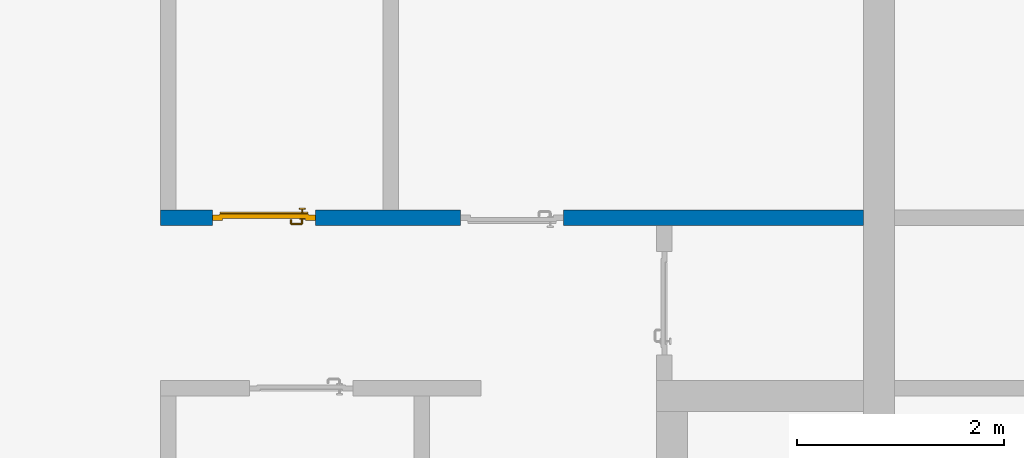
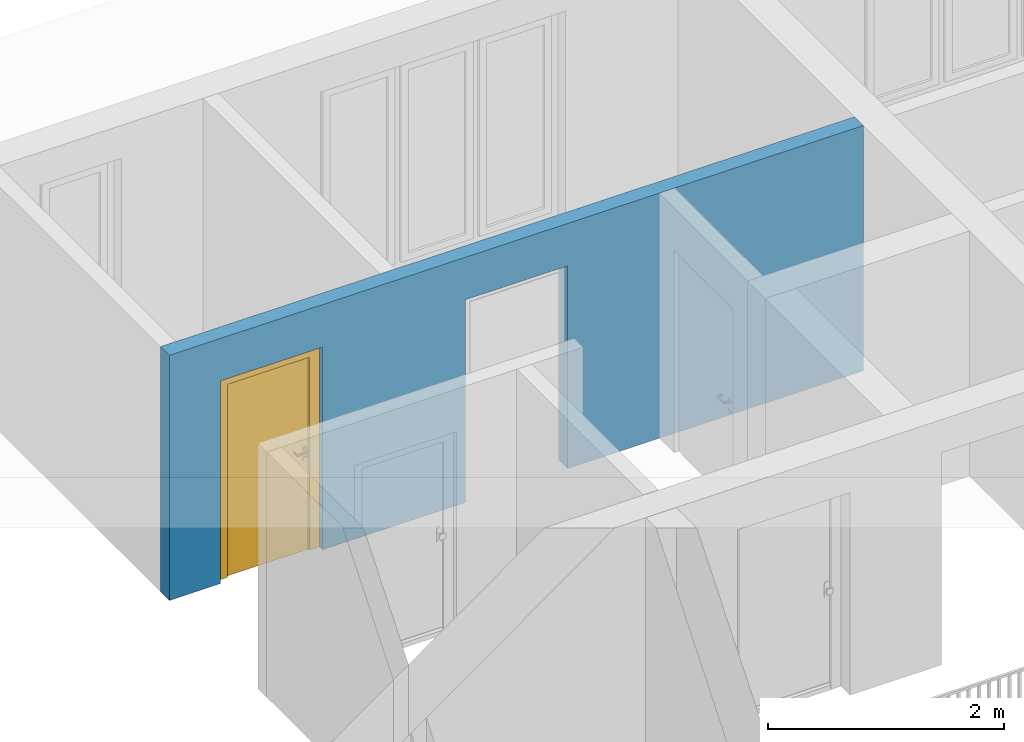
# One storey, part 25 of 54: 1 door, 1 wall, 2 openings.
"""IFC4 building model written with IfcOpenShell, lengths in metres."""

from ifc_helpers import new_model, entity, si_unit, converted_unit, derived_unit, direction, frame, origin_with_axes, place, context, subcontext, project, spatial, polygons, source, transform, mapped, material, type_object, element, fill, save


model = new_model("IFC4")

# Units and contexts
model_context = context("Model", 3, precision=1e-05, world=origin_with_axes(), true_north=direction((0.0, 1.0)))
body_context = subcontext(model_context, "Body", "Model", "MODEL_VIEW")
ifc_project = project(units=[si_unit("LENGTHUNIT", "METRE"), si_unit("AREAUNIT", "SQUARE_METRE"), si_unit("VOLUMEUNIT", "CUBIC_METRE"), converted_unit("PLANEANGLEUNIT", "DEGREE", entity("IfcPlaneAngleMeasure", 0.0174532925199), si_unit("PLANEANGLEUNIT", "RADIAN"), dimensions=[0, 0, 0, 0, 0, 0, 0]), converted_unit("TIMEUNIT", "Year", entity("IfcTimeMeasure", 31556926.0), si_unit("TIMEUNIT", "SECOND"), dimensions=[0, 0, 1, 0, 0, 0, 0]), si_unit("MASSUNIT", "GRAM", prefix="KILO"), si_unit("THERMODYNAMICTEMPERATUREUNIT", "DEGREE_CELSIUS"), si_unit("LUMINOUSINTENSITYUNIT", "LUMEN"), si_unit("ENERGYUNIT", "JOULE", prefix="MEGA"), derived_unit("THERMALCONDUCTANCEUNIT", [(si_unit("POWERUNIT", "WATT"), 1), (si_unit("LENGTHUNIT", "METRE"), -1), (si_unit("THERMODYNAMICTEMPERATUREUNIT", "KELVIN"), -1)]), derived_unit("SPECIFICHEATCAPACITYUNIT", [(si_unit("ENERGYUNIT", "JOULE"), 1), (si_unit("MASSUNIT", "GRAM", prefix="KILO"), -1), (si_unit("THERMODYNAMICTEMPERATUREUNIT", "KELVIN"), -1)]), derived_unit("MASSDENSITYUNIT", [(si_unit("MASSUNIT", "GRAM", prefix="KILO"), 1), (si_unit("VOLUMEUNIT", "CUBIC_METRE"), -1)])], contexts=[model_context])

# Site, building, storey
site_placement = place(None, origin_with_axes())
site = spatial("IfcSite", under=ifc_project, at=site_placement, CompositionType="ELEMENT")
building_placement = place(site_placement, origin_with_axes())
building = spatial("IfcBuilding", under=site, at=building_placement, CompositionType="ELEMENT")
storey_placement = place(building_placement, frame((0.0, 0.0, 9.18), z_axis=(0.0, 0.0, 1.0), x_axis=(1.0, 0.0, 0.0)))
storey = spatial("IfcBuildingStorey", under=building, at=storey_placement, Name="3. Geschoss", CompositionType="ELEMENT", Elevation=9.18)

# Wall, openings, door
ifc_material = material()
wall_type = type_object("IfcWallType", Name="150", PredefinedType="NOTDEFINED")
wall_placement = place(storey_placement, frame((-7.5421993804, 5.47118776896, 0.0), z_axis=(0.0, 0.0, 1.0), x_axis=(1.0, 0.0, 0.0)))
wall = element("IfcWall", 1, at=wall_placement, inside=storey, type_object=wall_type, material=ifc_material, Name="Wand-002", PredefinedType="NOTDEFINED", context=body_context, shape_type="Tessellation", body=[
    polygons([(2.9, 0.15, 2.1), (2.9, 0.15, 0.0), (1.5, 0.15, 0.0), (1.5, 0.15, 2.1), (0.5, 0.15, 2.1), (0.5, 0.15, 0.0), (0.0, 0.15, 0.0), (0.0, 0.15, 2.54), (6.8, 0.15, 2.54), (6.8, 0.15, 0.0), (3.9, 0.15, 0.0), (3.9, 0.15, 2.1), (2.9, 0.05, 2.1), (2.9, 0.05, 0.0), (2.9, 0.0, 0.0), (1.5, 0.0, 0.0), (1.5, 0.1, 0.0), (1.5, 0.1, 2.1), (0.5, 0.1, 2.1), (0.5, 0.1, 0.0), (0.5, 0.0, 0.0), (0.0, 0.0, 0.0), (0.0, 0.0, 2.54), (6.8, 0.0, 2.54), (6.8, 0.0, 0.0), (3.9, 0.05, 0.0), (3.9, 0.0, 0.0), (3.9, 0.05, 2.1), (2.9, 0.0, 2.1), (3.9, 0.0, 2.1), (0.5, 0.0, 2.1), (1.5, 0.0, 2.1)], [[[1, 2, 3, 4, 5, 6, 7, 8, 9, 10, 11, 12]], [[2, 1, 13, 14]], [[2, 14, 15, 16, 17, 3]], [[4, 3, 17, 18]], [[5, 4, 18, 19]], [[6, 5, 19, 20]], [[6, 20, 21, 22, 7]], [[22, 23, 8, 7]], [[23, 24, 9, 8]], [[10, 9, 24, 25]], [[26, 11, 10, 25, 27]], [[12, 11, 26, 28]], [[1, 12, 28, 13]], [[14, 13, 29, 15]], [[16, 15, 29, 30, 27, 25, 24, 23, 22, 21, 31, 32]], [[16, 32, 18, 17]], [[32, 31, 19, 18]], [[31, 21, 20, 19]], [[28, 26, 27, 30]], [[13, 28, 30, 29]]], closed=True),
])
opening_1_placement = place(wall_placement, frame((1.0, 0.0, 0.0), z_axis=(0.0, 0.0, 1.0), x_axis=(1.0, 0.0, 0.0)))
opening_1 = element("IfcOpeningElement", 2, at=opening_1_placement, cuts=wall, context=body_context, identifier="Reference", shape_type="Tessellation", body=[
    polygons([(-0.5, 0.1, 0.0), (-0.5, 0.1, 2.1), (-0.5, 0.151, 2.1), (-0.5, 0.151, 0.0), (-0.5, -0.001, 0.0), (-0.5, -0.001, 2.1), (0.5, 0.1, 2.1), (0.5, 0.151, 2.1), (0.5, -0.001, 2.1), (0.5, 0.151, 0.0), (0.5, 0.1, 0.0), (0.5, -0.001, 0.0)], [[[1, 2, 3, 4]], [[2, 1, 5, 6]], [[7, 8, 3, 2, 6, 9]], [[8, 10, 4, 3]], [[1, 4, 10, 11, 12, 5]], [[6, 5, 12, 9]], [[7, 11, 10, 8]], [[11, 7, 9, 12]]], closed=True),
])
opening_2_placement = place(wall_placement, frame((3.4, 0.0, 0.0), z_axis=(0.0, 0.0, 1.0), x_axis=(1.0, 0.0, 0.0)))
element("IfcOpeningElement", 3, at=opening_2_placement, cuts=wall, context=body_context, identifier="Reference", shape_type="Tessellation", body=[
    polygons([(0.5, 0.05, 0.0), (0.5, 0.05, 2.1), (0.5, -0.001, 2.1), (0.5, -0.001, 0.0), (0.5, 0.151, 0.0), (0.5, 0.151, 2.1), (-0.5, 0.05, 2.1), (-0.5, -0.001, 2.1), (-0.5, 0.151, 2.1), (-0.5, -0.001, 0.0), (-0.5, 0.05, 0.0), (-0.5, 0.151, 0.0)], [[[1, 2, 3, 4]], [[2, 1, 5, 6]], [[7, 8, 3, 2, 6, 9]], [[8, 10, 4, 3]], [[1, 4, 10, 11, 12, 5]], [[6, 5, 12, 9]], [[7, 11, 10, 8]], [[11, 7, 9, 12]]], closed=True),
])
door_type = type_object("IfcDoorType", Name="Eingang 01 1-Fl 26", OperationType="SINGLE_SWING_LEFT", PredefinedType="DOOR")
shared_shape = source(origin_with_axes(), body_context, "Body", "Tessellation", [
    polygons([(-0.5, -0.05, 0.0), (-0.5, -0.05, 2.1), (-0.5, -0.03, 2.1), (-0.5, -0.03, 0.0), (-0.4, -0.05, 0.0), (-0.4, -0.05, 2.0), (-0.1301, -0.05, 2.0), (-0.0001, -0.05, 2.0), (0.4, -0.05, 2.0), (0.4, -0.05, 0.0), (0.5, -0.05, 0.0), (0.5, -0.05, 2.1), (0.5, -0.03, 2.1), (0.5, -0.03, 0.0), (0.4, -0.03, 0.0), (0.4, -0.03, 2.0), (-0.0001, -0.03, 2.0), (-0.1301, -0.03, 2.0), (-0.4, -0.03, 2.0), (-0.4, -0.03, 0.0)], [[[1, 2, 3, 4]], [[1, 5, 6, 7, 8, 9, 10, 11, 12, 2]], [[2, 12, 13, 3]], [[4, 3, 13, 14, 15, 16, 17, 18, 19, 20]], [[5, 1, 4, 20]], [[6, 5, 20, 19]], [[7, 6, 19, 18]], [[8, 7, 18, 17]], [[9, 8, 17, 16]], [[10, 9, 16, 15]], [[11, 10, 15, 14]], [[12, 11, 14, 13]]], closed=True),
    polygons([(-0.5, -0.03, 0.0), (-0.5, -0.03, 2.1), (-0.5, 0.0, 2.1), (-0.5, 0.0, 0.0), (-0.43, -0.03, 0.0), (-0.43, -0.03, 2.03), (-0.1001, -0.03, 2.03), (-0.0301, -0.03, 2.03), (0.43, -0.03, 2.03), (0.43, -0.03, 0.0), (0.5, -0.03, 0.0), (0.5, -0.03, 2.1), (0.5, 0.0, 2.1), (0.5, 0.0, 0.0), (0.43, 0.0, 0.0), (0.43, 0.0, 2.03), (-0.0301, 0.0, 2.03), (-0.1001, 0.0, 2.03), (-0.43, 0.0, 2.03), (-0.43, 0.0, 0.0)], [[[1, 2, 3, 4]], [[1, 5, 6, 7, 8, 9, 10, 11, 12, 2]], [[2, 12, 13, 3]], [[4, 3, 13, 14, 15, 16, 17, 18, 19, 20]], [[5, 1, 4, 20]], [[6, 5, 20, 19]], [[7, 6, 19, 18]], [[8, 7, 18, 17]], [[9, 8, 17, 16]], [[10, 9, 16, 15]], [[11, 10, 15, 14]], [[12, 11, 14, 13]]], closed=True),
    polygons([(-0.43, 0.01, 0.0), (-0.43, 0.01, 2.03), (0.43, 0.01, 2.03), (0.43, 0.01, 0.0), (-0.43, -0.03, 0.0), (-0.43, -0.03, 2.03), (0.43, -0.03, 2.03), (0.43, -0.03, 0.0)], [[[1, 2, 3, 4]], [[1, 5, 6, 2]], [[2, 6, 7, 3]], [[3, 7, 8, 4]], [[4, 8, 5, 1]], [[8, 7, 6, 5]]], closed=True),
    polygons([(-0.425, 0.03, 0.0), (-0.425, 0.03, 0.05), (0.425, 0.03, 0.05), (0.425, 0.03, 0.0), (-0.425, 0.01, 0.0), (-0.425, 0.01, 0.07), (-0.425, 0.015, 0.07), (0.425, 0.015, 0.07), (0.425, 0.01, 0.07), (0.425, 0.01, 0.0)], [[[1, 2, 3, 4]], [[1, 5, 6, 7, 2]], [[2, 7, 8, 3]], [[4, 3, 8, 9, 10]], [[5, 1, 4, 10]], [[6, 5, 10, 9]], [[7, 6, 9, 8]]], closed=True),
    polygons([(0.3835, -0.04, 1.0733826859), (0.3835, -0.0399, 1.0733826859), (0.37, -0.0399, 1.077), (0.37, -0.04, 1.077), (0.393382685902, -0.04, 1.0635), (0.393382685902, -0.0399, 1.0635), (0.3835, -0.0301, 1.0733826859), (0.37, -0.0301, 1.077), (0.3565, -0.0399, 1.0733826859), (0.3565, -0.04, 1.0733826859), (0.346617314098, -0.04, 1.0635), (0.343, -0.04, 1.05), (0.346617314098, -0.04, 1.0365), (0.3565, -0.04, 1.0266173141), (0.37, -0.04, 1.023), (0.3835, -0.04, 1.0266173141), (0.393382685902, -0.04, 1.0365), (0.397, -0.04, 1.05), (0.397, -0.0399, 1.05), (0.393382685902, -0.0301, 1.0635), (0.3835, -0.03, 1.0733826859), (0.37, -0.03, 1.077), (0.3565, -0.0301, 1.0733826859), (0.346617314098, -0.0399, 1.0635), (0.343, -0.0399, 1.05), (0.346617314098, -0.0399, 1.0365), (0.3565, -0.0399, 1.0266173141), (0.37, -0.0399, 1.023), (0.3835, -0.0399, 1.0266173141), (0.393382685902, -0.0399, 1.0365), (0.397, -0.0301, 1.05), (0.393382685902, -0.03, 1.0635), (0.397, -0.03, 1.05), (0.393382685902, -0.03, 1.0365), (0.3835, -0.03, 1.0266173141), (0.37, -0.03, 1.023), (0.3565, -0.03, 1.0266173141), (0.346617314098, -0.03, 1.0365), (0.343, -0.03, 1.05), (0.346617314098, -0.03, 1.0635), (0.3565, -0.03, 1.0733826859), (0.346617314098, -0.0301, 1.0635), (0.343, -0.0301, 1.05), (0.346617314098, -0.0301, 1.0365), (0.3565, -0.0301, 1.0266173141), (0.37, -0.0301, 1.023), (0.3835, -0.0301, 1.0266173141), (0.393382685902, -0.0301, 1.0365)], [[[1, 2, 3, 4]], [[5, 6, 2, 1]], [[2, 7, 8, 3]], [[4, 3, 9, 10]], [[4, 10, 11, 12, 13, 14, 15, 16, 17, 18, 5, 1]], [[18, 19, 6, 5]], [[6, 20, 7, 2]], [[7, 21, 22, 8]], [[3, 8, 23, 9]], [[10, 9, 24, 11]], [[11, 24, 25, 12]], [[12, 25, 26, 13]], [[13, 26, 27, 14]], [[14, 27, 28, 15]], [[15, 28, 29, 16]], [[16, 29, 30, 17]], [[17, 30, 19, 18]], [[19, 31, 20, 6]], [[20, 32, 21, 7]], [[22, 21, 32, 33, 34, 35, 36, 37, 38, 39, 40, 41]], [[8, 22, 41, 23]], [[9, 23, 42, 24]], [[24, 42, 43, 25]], [[25, 43, 44, 26]], [[26, 44, 45, 27]], [[27, 45, 46, 28]], [[28, 46, 47, 29]], [[29, 47, 48, 30]], [[30, 48, 31, 19]], [[31, 33, 32, 20]], [[48, 34, 33, 31]], [[47, 35, 34, 48]], [[46, 36, 35, 47]], [[45, 37, 36, 46]], [[44, 38, 37, 45]], [[43, 39, 38, 44]], [[42, 40, 39, 43]], [[23, 41, 40, 42]]], closed=True),
    polygons([(0.362532169224, -0.04, 0.959692280177), (0.363279754556, -0.04, 0.961639806549), (0.35655, -0.04, 0.973296083362), (0.346703916638, -0.04, 0.96345), (0.365, -0.04, 0.952886751346), (0.365, -0.04, 0.9544), (0.362532169224, -0.039, 0.959692280177), (0.363279754556, -0.039, 0.961639806549), (0.364624817685, -0.039, 0.965143815798), (0.364624817685, -0.04, 0.965143815798), (0.37, -0.04, 0.967425445323), (0.37, -0.04, 0.9769), (0.346617314098, -0.04, 0.9635), (0.3565, -0.04, 0.973382685902), (0.365, -0.04, 0.95), (0.3431, -0.04, 0.95), (0.365, -0.04, 0.947113248654), (0.365, -0.04, 0.941339745962), (0.365, -0.04, 0.9375), (0.365, -0.039, 0.9375), (0.365, -0.039, 0.941339745962), (0.365, -0.039, 0.947113248654), (0.365, -0.039, 0.95), (0.365, -0.039, 0.952886751346), (0.365, -0.039, 0.9544), (0.347569942042, -0.039, 0.96295), (0.35705, -0.039, 0.972430057958), (0.37, -0.039, 0.9759), (0.37, -0.039, 0.967425445323), (0.375375182315, -0.04, 0.965143815798), (0.376720245444, -0.04, 0.961639806549), (0.38345, -0.04, 0.973296083362), (0.37, -0.04, 0.977), (0.343, -0.04, 0.95), (0.346617314098, -0.0399, 0.9635), (0.3565, -0.0399, 0.973382685902), (0.346703916638, -0.04, 0.93655), (0.35655, -0.04, 0.926703916638), (0.37, -0.04, 0.9231), (0.37, -0.04, 0.9325), (0.366464466094, -0.04, 0.933964466094), (0.366464466094, -0.039, 0.933964466094), (0.37, -0.039, 0.9241), (0.35705, -0.039, 0.927569942042), (0.37, -0.039, 0.9325), (0.347569942042, -0.039, 0.93705), (0.3441, -0.039, 0.95), (0.347483339502, -0.039, 0.963), (0.357, -0.039, 0.972516660498), (0.37, -0.039, 0.976), (0.375375182315, -0.039, 0.965143815798), (0.38295, -0.039, 0.972430057958), (0.376720245444, -0.039, 0.961639806549), (0.377467830776, -0.039, 0.959692280177), (0.377467830776, -0.04, 0.959692280177), (0.375, -0.04, 0.9544), (0.375, -0.04, 0.952886751346), (0.393296083362, -0.04, 0.96345), (0.3835, -0.04, 0.973382685902), (0.37, -0.0399, 0.977), (0.346617314098, -0.04, 0.9365), (0.343, -0.0399, 0.95), (0.346617314098, -0.0301, 0.9635), (0.3565, -0.0301, 0.973382685902), (0.3565, -0.04, 0.926617314098), (0.37, -0.04, 0.923), (0.38345, -0.04, 0.926703916638), (0.375, -0.04, 0.941339745962), (0.375, -0.04, 0.9375), (0.373535533906, -0.04, 0.933964466094), (0.37, -0.039, 0.924), (0.357, -0.039, 0.927483339502), (0.38295, -0.039, 0.927569942042), (0.373535533906, -0.039, 0.933964466094), (0.375, -0.039, 0.9375), (0.375, -0.039, 0.941339745962), (0.347483339502, -0.039, 0.937), (0.344, -0.039, 0.95), (0.347483339502, -0.0389, 0.963), (0.357, -0.0389, 0.972516660498), (0.37, -0.0389, 0.976), (0.383, -0.039, 0.972516660498), (0.392430057958, -0.039, 0.96295), (0.375, -0.039, 0.952886751346), (0.375, -0.039, 0.9544), (0.375, -0.039, 0.95), (0.375, -0.039, 0.947113248654), (0.375, -0.04, 0.947113248654), (0.375, -0.04, 0.95), (0.3969, -0.04, 0.95), (0.393382685902, -0.04, 0.9635), (0.3835, -0.0399, 0.973382685902), (0.37, -0.0301, 0.977), (0.346617314098, -0.0399, 0.9365), (0.343, -0.0301, 0.95), (0.346617314098, -0.03, 0.9635), (0.3565, -0.03, 0.973382685902), (0.3565, -0.0399, 0.926617314098), (0.3835, -0.04, 0.926617314098), (0.37, -0.0399, 0.923), (0.393296083362, -0.04, 0.93655), (0.383, -0.039, 0.927483339502), (0.37, -0.0389, 0.924), (0.357, -0.0389, 0.927483339502), (0.392430057958, -0.039, 0.93705), (0.347483339502, -0.0389, 0.937), (0.344, -0.0389, 0.95), (0.347483339502, -0.0301, 0.963), (0.357, -0.0301, 0.972516660498), (0.37, -0.0301, 0.976), (0.383, -0.0389, 0.972516660498), (0.392516660498, -0.039, 0.963), (0.3959, -0.039, 0.95), (0.397, -0.04, 0.95), (0.393382685902, -0.0399, 0.9635), (0.3835, -0.0301, 0.973382685902), (0.37, -0.03, 0.977), (0.346617314098, -0.0301, 0.9365), (0.343, -0.03, 0.95), (0.346703916638, -0.03, 0.96345), (0.35655, -0.03, 0.973296083362), (0.3565, -0.0301, 0.926617314098), (0.393382685902, -0.04, 0.9365), (0.3835, -0.0399, 0.926617314098), (0.37, -0.0301, 0.923), (0.392516660498, -0.039, 0.937), (0.383, -0.0389, 0.927483339502), (0.37, -0.0301, 0.924), (0.357, -0.0301, 0.927483339502), (0.347483339502, -0.0301, 0.937), (0.344, -0.0301, 0.95), (0.347483339502, -0.03, 0.963), (0.357, -0.03, 0.972516660498), (0.37, -0.03, 0.976), (0.383, -0.0301, 0.972516660498), (0.392516660498, -0.0389, 0.963), (0.396, -0.039, 0.95), (0.397, -0.0399, 0.95), (0.393382685902, -0.0301, 0.9635), (0.3835, -0.03, 0.973382685902), (0.37, -0.03, 0.9769), (0.346617314098, -0.03, 0.9365), (0.3431, -0.03, 0.95), (0.347396736961, -0.03, 0.96305), (0.35695, -0.03, 0.972603263039), (0.3565, -0.03, 0.926617314098), (0.393382685902, -0.0399, 0.9365), (0.3835, -0.0301, 0.926617314098), (0.37, -0.03, 0.923), (0.392516660498, -0.0389, 0.937), (0.383, -0.0301, 0.927483339502), (0.37, -0.03, 0.924), (0.357, -0.03, 0.927483339502), (0.347483339502, -0.03, 0.937), (0.344, -0.03, 0.95), (0.37, -0.03, 0.9761), (0.383, -0.03, 0.972516660498), (0.392516660498, -0.0301, 0.963), (0.396, -0.0389, 0.95), (0.397, -0.0301, 0.95), (0.393382685902, -0.03, 0.9635), (0.38345, -0.03, 0.973296083362), (0.346703916638, -0.03, 0.93655), (0.3439, -0.03, 0.95), (0.35655, -0.03, 0.926703916638), (0.393382685902, -0.0301, 0.9365), (0.3835, -0.03, 0.926617314098), (0.37, -0.03, 0.9231), (0.392516660498, -0.0301, 0.937), (0.383, -0.03, 0.927483339502), (0.37, -0.03, 0.9239), (0.35695, -0.03, 0.927396736961), (0.347396736961, -0.03, 0.93695), (0.38305, -0.03, 0.972603263039), (0.392516660498, -0.03, 0.963), (0.396, -0.0301, 0.95), (0.397, -0.03, 0.95), (0.393296083362, -0.03, 0.96345), (0.393382685902, -0.03, 0.9365), (0.38345, -0.03, 0.926703916638), (0.392516660498, -0.03, 0.937), (0.38305, -0.03, 0.927396736961), (0.392603263039, -0.03, 0.96305), (0.396, -0.03, 0.95), (0.3969, -0.03, 0.95), (0.393296083362, -0.03, 0.93655), (0.392603263039, -0.03, 0.93695), (0.3961, -0.03, 0.95)], [[[1, 2, 3, 4, 5, 6]], [[1, 7, 8, 9, 10, 2]], [[10, 11, 12, 3, 2]], [[13, 4, 3, 14]], [[15, 5, 4, 16]], [[6, 5, 15, 17, 18, 19, 20, 21, 22, 23, 24, 25]], [[6, 25, 7, 1]], [[7, 25, 24, 26, 27, 8]], [[9, 8, 27, 28, 29]], [[10, 9, 29, 11]], [[30, 31, 32, 12, 11]], [[14, 3, 12, 33]], [[34, 16, 4, 13]], [[35, 13, 14, 36]], [[17, 15, 16, 37]], [[18, 17, 37, 38]], [[38, 39, 40, 41, 19, 18]], [[19, 41, 42, 20]], [[43, 44, 21, 20, 42, 45]], [[22, 21, 44, 46]], [[23, 22, 46, 47]], [[24, 23, 47, 26]], [[26, 48, 49, 27]], [[27, 49, 50, 28]], [[51, 29, 28, 52, 53]], [[11, 29, 51, 30]], [[30, 51, 53, 54, 55, 31]], [[55, 56, 57, 58, 32, 31]], [[33, 12, 32, 59]], [[36, 14, 33, 60]], [[61, 37, 16, 34]], [[62, 34, 13, 35]], [[63, 35, 36, 64]], [[65, 38, 37, 61]], [[66, 39, 38, 65]], [[39, 67, 68, 69, 70, 40]], [[41, 40, 45, 42]], [[43, 71, 72, 44]], [[73, 43, 45, 74, 75, 76]], [[44, 72, 77, 46]], [[46, 77, 78, 47]], [[47, 78, 48, 26]], [[48, 79, 80, 49]], [[49, 80, 81, 50]], [[28, 50, 82, 52]], [[54, 53, 52, 83, 84, 85]], [[55, 54, 85, 56]], [[85, 84, 86, 87, 76, 75, 69, 68, 88, 89, 57, 56]], [[57, 89, 90, 58]], [[59, 32, 58, 91]], [[60, 33, 59, 92]], [[64, 36, 60, 93]], [[94, 61, 34, 62]], [[95, 62, 35, 63]], [[96, 63, 64, 97]], [[98, 65, 61, 94]], [[99, 67, 39, 66]], [[100, 66, 65, 98]], [[88, 68, 67, 101]], [[70, 69, 75, 74]], [[40, 70, 74, 45]], [[73, 102, 71, 43]], [[71, 103, 104, 72]], [[76, 87, 105, 73]], [[72, 104, 106, 77]], [[77, 106, 107, 78]], [[78, 107, 79, 48]], [[79, 108, 109, 80]], [[80, 109, 110, 81]], [[50, 81, 111, 82]], [[52, 82, 112, 83]], [[86, 84, 83, 113]], [[87, 86, 113, 105]], [[89, 88, 101, 90]], [[91, 58, 90, 114]], [[92, 59, 91, 115]], [[93, 60, 92, 116]], [[97, 64, 93, 117]], [[118, 94, 62, 95]], [[119, 95, 63, 96]], [[120, 96, 97, 121]], [[122, 98, 94, 118]], [[123, 101, 67, 99]], [[124, 99, 66, 100]], [[125, 100, 98, 122]], [[105, 126, 102, 73]], [[102, 127, 103, 71]], [[103, 128, 129, 104]], [[104, 129, 130, 106]], [[106, 130, 131, 107]], [[107, 131, 108, 79]], [[108, 132, 133, 109]], [[109, 133, 134, 110]], [[81, 110, 135, 111]], [[82, 111, 136, 112]], [[83, 112, 137, 113]], [[113, 137, 126, 105]], [[114, 90, 101, 123]], [[115, 91, 114, 138]], [[116, 92, 115, 139]], [[117, 93, 116, 140]], [[121, 97, 117, 141]], [[142, 118, 95, 119]], [[143, 119, 96, 120]], [[144, 120, 121, 145]], [[146, 122, 118, 142]], [[147, 123, 99, 124]], [[148, 124, 100, 125]], [[149, 125, 122, 146]], [[126, 150, 127, 102]], [[127, 151, 128, 103]], [[128, 152, 153, 129]], [[129, 153, 154, 130]], [[130, 154, 155, 131]], [[131, 155, 132, 108]], [[132, 144, 145, 133]], [[133, 145, 156, 134]], [[110, 134, 157, 135]], [[111, 135, 158, 136]], [[112, 136, 159, 137]], [[137, 159, 150, 126]], [[138, 114, 123, 147]], [[139, 115, 138, 160]], [[140, 116, 139, 161]], [[141, 117, 140, 162]], [[145, 121, 141, 156]], [[163, 142, 119, 143]], [[164, 143, 120, 144]], [[165, 146, 142, 163]], [[166, 147, 124, 148]], [[167, 148, 125, 149]], [[168, 149, 146, 165]], [[150, 169, 151, 127]], [[151, 170, 152, 128]], [[152, 171, 172, 153]], [[153, 172, 173, 154]], [[154, 173, 164, 155]], [[155, 164, 144, 132]], [[134, 156, 174, 157]], [[135, 157, 175, 158]], [[136, 158, 176, 159]], [[159, 176, 169, 150]], [[160, 138, 147, 166]], [[161, 139, 160, 177]], [[162, 140, 161, 178]], [[156, 141, 162, 174]], [[173, 163, 143, 164]], [[172, 165, 163, 173]], [[179, 166, 148, 167]], [[180, 167, 149, 168]], [[171, 168, 165, 172]], [[169, 181, 170, 151]], [[170, 182, 171, 152]], [[157, 174, 183, 175]], [[158, 175, 184, 176]], [[176, 184, 181, 169]], [[177, 160, 166, 179]], [[178, 161, 177, 185]], [[174, 162, 178, 183]], [[186, 179, 167, 180]], [[182, 180, 168, 171]], [[181, 187, 182, 170]], [[175, 183, 188, 184]], [[184, 188, 187, 181]], [[185, 177, 179, 186]], [[183, 178, 185, 188]], [[187, 186, 180, 182]], [[188, 185, 186, 187]]], closed=True),
    polygons([(0.38, -0.04, 1.05), (0.38, -0.0709849140336, 1.05), (0.377071067812, -0.070696439392, 1.04292893219), (0.377071067812, -0.04, 1.04292893219), (0.377071067812, -0.04, 1.05707106781), (0.377071067812, -0.070696439392, 1.05707106781), (0.378277987014, -0.0796420579258, 1.05), (0.375518993221, -0.0784992452783, 1.04292893219), (0.37, -0.07, 1.04), (0.37, -0.04, 1.04), (0.37, -0.04, 1.06), (0.37, -0.07, 1.06), (0.375518993221, -0.0784992452783, 1.05707106781), (0.372816199938, -0.0878161999379, 1.05), (0.370704557509, -0.0857045575088, 1.04292893219), (0.368858192988, -0.0757402514855, 1.04), (0.362928932188, -0.069303560608, 1.04292893219), (0.362928932188, -0.04, 1.04292893219), (0.362928932188, -0.04, 1.05707106781), (0.362928932188, -0.069303560608, 1.05707106781), (0.368858192988, -0.0757402514855, 1.06), (0.370704557509, -0.0857045575088, 1.05707106781), (0.364642057926, -0.0932779870137, 1.05), (0.363499245278, -0.0905189932208, 1.04292893219), (0.365606601718, -0.0806066017178, 1.04), (0.362197392755, -0.0729812576926, 1.04292893219), (0.36, -0.0690150859664, 1.05), (0.36, -0.04, 1.05), (0.362197392755, -0.0729812576926, 1.05707106781), (0.365606601718, -0.0806066017178, 1.06), (0.363499245278, -0.0905189932208, 1.05707106781), (0.355984914034, -0.095, 1.05), (0.355696439392, -0.0920710678119, 1.04292893219), (0.360740251485, -0.0838581929877, 1.04), (0.360508645927, -0.0755086459268, 1.04292893219), (0.359438398962, -0.0718384450452, 1.05), (0.360508645927, -0.0755086459268, 1.05707106781), (0.360740251485, -0.0838581929877, 1.06), (0.355696439392, -0.0920710678119, 1.05707106781), (0.274015085966, -0.095, 1.05), (0.274303560608, -0.0920710678119, 1.04292893219), (0.355, -0.085, 1.04), (0.357981257693, -0.0771973927545, 1.04292893219), (0.358397003498, -0.0733970034977, 1.05), (0.357981257693, -0.0771973927545, 1.05707106781), (0.355, -0.085, 1.06), (0.274303560608, -0.0920710678119, 1.05707106781), (0.265357942074, -0.0932779870137, 1.05), (0.266500754722, -0.0905189932208, 1.04292893219), (0.275, -0.085, 1.04), (0.354303560608, -0.0779289321881, 1.04292893219), (0.356838445045, -0.0744383989617, 1.05), (0.354303560608, -0.0779289321881, 1.05707106781), (0.275, -0.085, 1.06), (0.266500754722, -0.0905189932208, 1.05707106781), (0.257183800062, -0.0878161999379, 1.05), (0.259295442491, -0.0857045575088, 1.04292893219), (0.269259748515, -0.0838581929877, 1.04), (0.275696439392, -0.0779289321881, 1.04292893219), (0.354015085966, -0.075, 1.05), (0.275696439392, -0.0779289321881, 1.05707106781), (0.269259748515, -0.0838581929877, 1.06), (0.259295442491, -0.0857045575088, 1.05707106781), (0.251722012986, -0.0796420579258, 1.05), (0.254481006779, -0.0784992452783, 1.04292893219), (0.264393398282, -0.0806066017178, 1.04), (0.272018742307, -0.0771973927545, 1.04292893219), (0.275984914034, -0.075, 1.05), (0.272018742307, -0.0771973927545, 1.05707106781), (0.264393398282, -0.0806066017178, 1.06), (0.254481006779, -0.0784992452783, 1.05707106781), (0.25, -0.0709849140336, 1.05), (0.252928932188, -0.070696439392, 1.04292893219), (0.261141807012, -0.0757402514855, 1.04), (0.269491354073, -0.0755086459268, 1.04292893219), (0.273161554955, -0.0744383989617, 1.05), (0.269491354073, -0.0755086459268, 1.05707106781), (0.261141807012, -0.0757402514855, 1.06), (0.252928932188, -0.070696439392, 1.05707106781), (0.25, -0.04, 1.05), (0.252928932188, -0.04, 1.04292893219), (0.26, -0.07, 1.04), (0.267802607245, -0.0729812576926, 1.04292893219), (0.271602996502, -0.0733970034977, 1.05), (0.267802607245, -0.0729812576926, 1.05707106781), (0.26, -0.07, 1.06), (0.252928932188, -0.04, 1.05707106781), (0.26, -0.04, 1.06), (0.267071067812, -0.04, 1.05707106781), (0.27, -0.04, 1.05), (0.267071067812, -0.04, 1.04292893219), (0.26, -0.04, 1.04), (0.267071067812, -0.069303560608, 1.04292893219), (0.270561601038, -0.0718384450452, 1.05), (0.267071067812, -0.069303560608, 1.05707106781), (0.27, -0.0690150859664, 1.05)], [[[1, 2, 3, 4]], [[5, 6, 2, 1]], [[2, 7, 8, 3]], [[4, 3, 9, 10]], [[11, 12, 6, 5]], [[6, 13, 7, 2]], [[7, 14, 15, 8]], [[3, 8, 16, 9]], [[10, 9, 17, 18]], [[19, 20, 12, 11]], [[12, 21, 13, 6]], [[13, 22, 14, 7]], [[14, 23, 24, 15]], [[8, 15, 25, 16]], [[9, 16, 26, 17]], [[18, 17, 27, 28]], [[28, 27, 20, 19]], [[20, 29, 21, 12]], [[21, 30, 22, 13]], [[22, 31, 23, 14]], [[23, 32, 33, 24]], [[15, 24, 34, 25]], [[16, 25, 35, 26]], [[17, 26, 36, 27]], [[27, 36, 29, 20]], [[29, 37, 30, 21]], [[30, 38, 31, 22]], [[31, 39, 32, 23]], [[32, 40, 41, 33]], [[24, 33, 42, 34]], [[25, 34, 43, 35]], [[26, 35, 44, 36]], [[36, 44, 37, 29]], [[37, 45, 38, 30]], [[38, 46, 39, 31]], [[39, 47, 40, 32]], [[40, 48, 49, 41]], [[33, 41, 50, 42]], [[34, 42, 51, 43]], [[35, 43, 52, 44]], [[44, 52, 45, 37]], [[45, 53, 46, 38]], [[46, 54, 47, 39]], [[47, 55, 48, 40]], [[48, 56, 57, 49]], [[41, 49, 58, 50]], [[42, 50, 59, 51]], [[43, 51, 60, 52]], [[52, 60, 53, 45]], [[53, 61, 54, 46]], [[54, 62, 55, 47]], [[55, 63, 56, 48]], [[56, 64, 65, 57]], [[49, 57, 66, 58]], [[50, 58, 67, 59]], [[51, 59, 68, 60]], [[60, 68, 61, 53]], [[61, 69, 62, 54]], [[62, 70, 63, 55]], [[63, 71, 64, 56]], [[64, 72, 73, 65]], [[57, 65, 74, 66]], [[58, 66, 75, 67]], [[59, 67, 76, 68]], [[68, 76, 69, 61]], [[69, 77, 70, 62]], [[70, 78, 71, 63]], [[71, 79, 72, 64]], [[72, 80, 81, 73]], [[65, 73, 82, 74]], [[66, 74, 83, 75]], [[67, 75, 84, 76]], [[76, 84, 77, 69]], [[77, 85, 78, 70]], [[78, 86, 79, 71]], [[79, 87, 80, 72]], [[80, 87, 88, 89, 90, 91, 92, 81]], [[73, 81, 92, 82]], [[74, 82, 93, 83]], [[75, 83, 94, 84]], [[84, 94, 85, 77]], [[85, 95, 86, 78]], [[86, 88, 87, 79]], [[95, 89, 88, 86]], [[96, 90, 89, 95]], [[93, 91, 90, 96]], [[82, 92, 91, 93]], [[83, 93, 96, 94]], [[94, 96, 95, 85]]], closed=False),
    polygons([(0.364696699141, 0.015, 1.04469669914), (0.37, 0.015, 1.0425), (0.375303300859, 0.015, 1.04469669914), (0.3775, 0.015, 1.05), (0.375303300859, 0.015, 1.05530330086), (0.37, 0.015, 1.0575), (0.364696699141, 0.015, 1.05530330086), (0.3625, 0.015, 1.05), (0.364696699141, 0.055, 1.04469669914), (0.37, 0.055, 1.0425), (0.375303300859, 0.055, 1.04469669914), (0.3775, 0.055, 1.05), (0.375303300859, 0.055, 1.05530330086), (0.37, 0.055, 1.0575), (0.364696699141, 0.055, 1.05530330086), (0.3625, 0.055, 1.05)], [[[1, 2, 3, 4, 5, 6, 7, 8]], [[2, 1, 9, 10]], [[3, 2, 10, 11]], [[4, 3, 11, 12]], [[5, 4, 12, 13]], [[6, 5, 13, 14]], [[7, 6, 14, 15]], [[8, 7, 15, 16]], [[1, 8, 16, 9]], [[9, 16, 15, 14, 13, 12, 11, 10]]], closed=True),
    polygons([(0.395, 0.01, 0.975), (0.393096988313, 0.01, 0.965432914191), (0.393096988313, 0.015, 0.965432914191), (0.395, 0.015, 0.975), (0.395, 0.01, 1.1), (0.393096988313, 0.01, 1.10956708581), (0.38767766953, 0.01, 1.11767766953), (0.379567085809, 0.01, 1.12309698831), (0.37, 0.01, 1.125), (0.360432914191, 0.01, 1.12309698831), (0.35232233047, 0.01, 1.11767766953), (0.346903011687, 0.01, 1.10956708581), (0.345, 0.01, 1.1), (0.345, 0.01, 0.975), (0.346903011687, 0.01, 0.965432914191), (0.35232233047, 0.01, 0.95732233047), (0.360432914191, 0.01, 0.951903011687), (0.37, 0.01, 0.95), (0.379567085809, 0.01, 0.951903011687), (0.38767766953, 0.01, 0.95732233047), (0.38767766953, 0.015, 0.95732233047), (0.379567085809, 0.015, 0.951903011687), (0.37, 0.015, 0.95), (0.360432914191, 0.015, 0.951903011687), (0.35232233047, 0.015, 0.95732233047), (0.346903011687, 0.015, 0.965432914191), (0.345, 0.015, 0.975), (0.345, 0.015, 1.1), (0.346903011687, 0.015, 1.10956708581), (0.35232233047, 0.015, 1.11767766953), (0.360432914191, 0.015, 1.12309698831), (0.37, 0.015, 1.125), (0.379567085809, 0.015, 1.12309698831), (0.38767766953, 0.015, 1.11767766953), (0.393096988313, 0.015, 1.10956708581), (0.395, 0.015, 1.1)], [[[1, 2, 3, 4]], [[1, 5, 6, 7, 8, 9, 10, 11, 12, 13, 14, 15, 16, 17, 18, 19, 20, 2]], [[2, 20, 21, 3]], [[4, 3, 21, 22, 23, 24, 25, 26, 27, 28, 29, 30, 31, 32, 33, 34, 35, 36]], [[5, 1, 4, 36]], [[6, 5, 36, 35]], [[7, 6, 35, 34]], [[8, 7, 34, 33]], [[9, 8, 33, 32]], [[10, 9, 32, 31]], [[11, 10, 31, 30]], [[12, 11, 30, 29]], [[13, 12, 29, 28]], [[14, 13, 28, 27]], [[15, 14, 27, 26]], [[16, 15, 26, 25]], [[17, 16, 25, 24]], [[18, 17, 24, 23]], [[19, 18, 23, 22]], [[20, 19, 22, 21]]], closed=True),
    polygons([(0.39, 0.055, 1.08), (0.395, 0.055, 1.07866025404), (0.395, 0.07, 1.07866025404), (0.39, 0.07, 1.08), (0.35, 0.055, 1.08), (0.345, 0.055, 1.07866025404), (0.341339745962, 0.055, 1.075), (0.34, 0.055, 1.07), (0.34, 0.055, 1.03), (0.341339745962, 0.055, 1.025), (0.345, 0.055, 1.02133974596), (0.35, 0.055, 1.02), (0.39, 0.055, 1.02), (0.395, 0.055, 1.02133974596), (0.398660254038, 0.055, 1.025), (0.4, 0.055, 1.03), (0.4, 0.055, 1.07), (0.398660254038, 0.055, 1.075), (0.398660254038, 0.07, 1.075), (0.4, 0.07, 1.07), (0.4, 0.07, 1.03), (0.398660254038, 0.07, 1.025), (0.395, 0.07, 1.02133974596), (0.39, 0.07, 1.02), (0.35, 0.07, 1.02), (0.345, 0.07, 1.02133974596), (0.341339745962, 0.07, 1.025), (0.34, 0.07, 1.03), (0.34, 0.07, 1.07), (0.341339745962, 0.07, 1.075), (0.345, 0.07, 1.07866025404), (0.35, 0.07, 1.08)], [[[1, 2, 3, 4]], [[1, 5, 6, 7, 8, 9, 10, 11, 12, 13, 14, 15, 16, 17, 18, 2]], [[2, 18, 19, 3]], [[4, 3, 19, 20, 21, 22, 23, 24, 25, 26, 27, 28, 29, 30, 31, 32]], [[5, 1, 4, 32]], [[6, 5, 32, 31]], [[7, 6, 31, 30]], [[8, 7, 30, 29]], [[9, 8, 29, 28]], [[10, 9, 28, 27]], [[11, 10, 27, 26]], [[12, 11, 26, 25]], [[13, 12, 25, 24]], [[14, 13, 24, 23]], [[15, 14, 23, 22]], [[16, 15, 22, 21]], [[17, 16, 21, 20]], [[18, 17, 20, 19]]], closed=True),
])
door_placement = place(opening_1_placement, frame((-0.4, 0.0, 0.0), z_axis=(0.0, 0.0, 1.0), x_axis=(1.0, 0.0, 0.0)))
door = element("IfcDoor", 4, at=door_placement, inside=storey, type_object=door_type, OverallHeight=2.1, OverallWidth=1.0, PredefinedType="DOOR", context=body_context, shape_type="MappedRepresentation", body=[
    mapped(shared_shape, transform((0.4, 0.1, 0.0))),
])
fill(opening_1, door)

save(model, "model.ifc")
